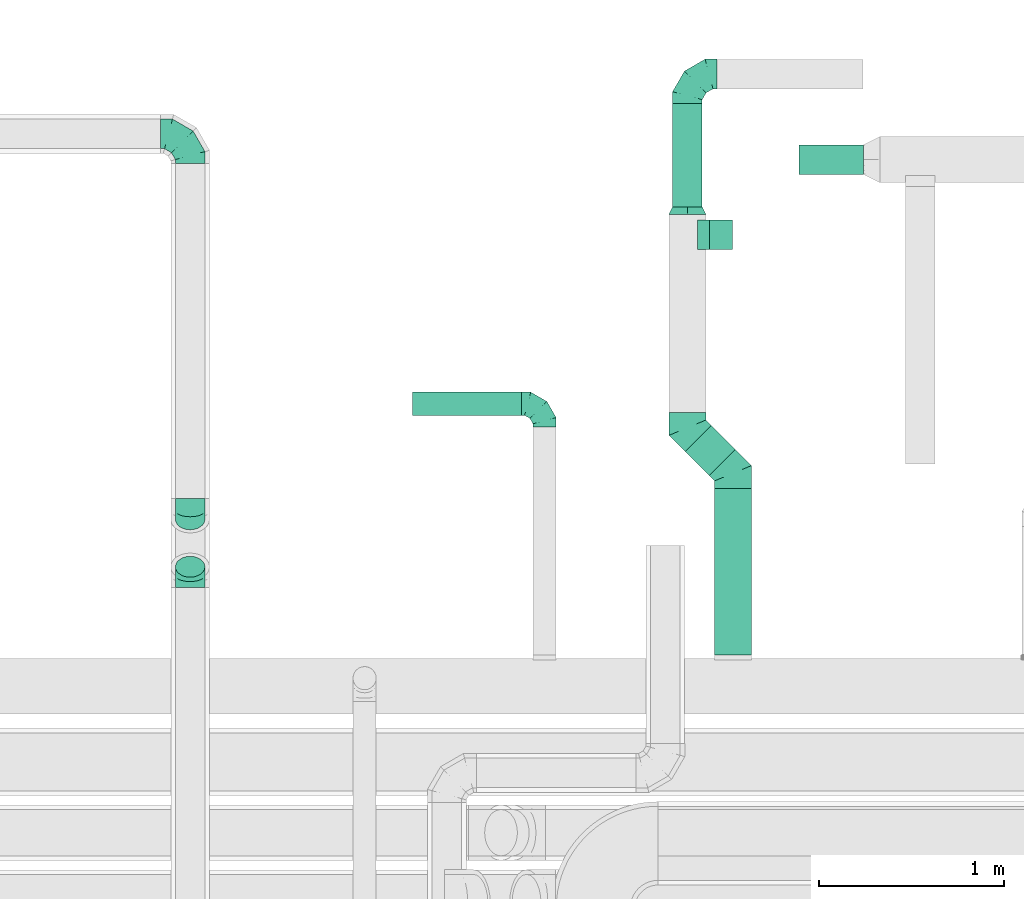
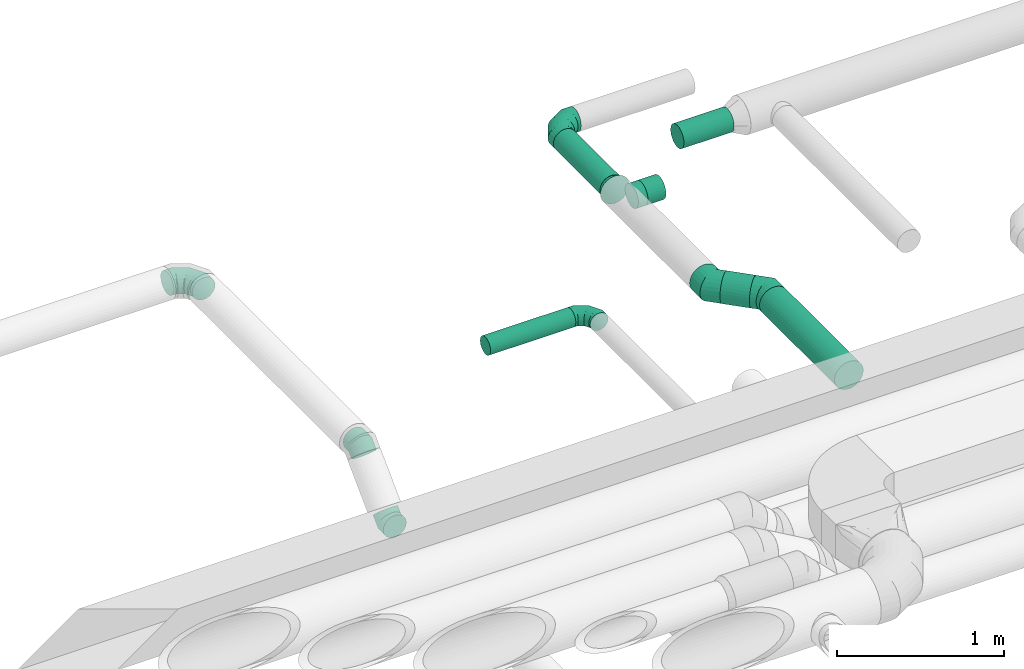
# One storey, part 77 of 92: 9 flow fittings, 6 flow segments.
"""IFC2X3 building model written with IfcOpenShell, lengths in millimetres."""

from ifc_helpers import new_model, entity, si_unit, converted_unit, derived_unit, direction, frame, origin, origin_2d_with_axis, place, context, subcontext, project, spatial, circle, extrude, faceted_brep, source, transform, mapped, material, type_object, type_shapes, element, save


model = new_model("IFC2X3")

# Units and contexts
model_context = context("Model", 3, precision=0.01, world=origin(), true_north=direction((6.12303176911189e-17, 1.0)))
body_context = subcontext(model_context, "Body", "Model", "MODEL_VIEW")
ifc_project = project(units=[si_unit("LENGTHUNIT", "METRE", prefix="MILLI"), si_unit("AREAUNIT", "SQUARE_METRE"), si_unit("VOLUMEUNIT", "CUBIC_METRE"), converted_unit("PLANEANGLEUNIT", "DEGREE", entity("IfcRatioMeasure", 0.0174532925199433), si_unit("PLANEANGLEUNIT", "RADIAN"), dimensions=[0, 0, 0, 0, 0, 0, 0]), si_unit("MASSUNIT", "GRAM", prefix="KILO"), derived_unit("MASSDENSITYUNIT", [(si_unit("MASSUNIT", "GRAM", prefix="KILO"), 1), (si_unit("LENGTHUNIT", "METRE"), -3)]), derived_unit("MOMENTOFINERTIAUNIT", [(si_unit("LENGTHUNIT", "METRE"), 4)]), si_unit("TIMEUNIT", "SECOND"), si_unit("FREQUENCYUNIT", "HERTZ"), si_unit("THERMODYNAMICTEMPERATUREUNIT", "DEGREE_CELSIUS"), derived_unit("THERMALTRANSMITTANCEUNIT", [(si_unit("MASSUNIT", "GRAM", prefix="KILO"), 1), (si_unit("THERMODYNAMICTEMPERATUREUNIT", "KELVIN"), -1), (si_unit("TIMEUNIT", "SECOND"), -3)]), derived_unit("VOLUMETRICFLOWRATEUNIT", [(si_unit("LENGTHUNIT", "METRE"), 3), (si_unit("TIMEUNIT", "SECOND"), -1)]), derived_unit("MASSFLOWRATEUNIT", [(si_unit("MASSUNIT", "GRAM", prefix="KILO"), 1), (si_unit("TIMEUNIT", "SECOND"), -1)]), derived_unit("ROTATIONALFREQUENCYUNIT", [(si_unit("TIMEUNIT", "SECOND"), -1)]), si_unit("ELECTRICCURRENTUNIT", "AMPERE"), si_unit("ELECTRICVOLTAGEUNIT", "VOLT"), si_unit("POWERUNIT", "WATT"), si_unit("FORCEUNIT", "NEWTON", prefix="KILO"), si_unit("ILLUMINANCEUNIT", "LUX"), si_unit("LUMINOUSFLUXUNIT", "LUMEN"), si_unit("LUMINOUSINTENSITYUNIT", "CANDELA"), derived_unit("USERDEFINED", [(si_unit("MASSUNIT", "GRAM", prefix="KILO"), -1), (si_unit("LENGTHUNIT", "METRE"), -2), (si_unit("TIMEUNIT", "SECOND"), 3), (si_unit("LUMINOUSFLUXUNIT", "LUMEN"), 1)]), derived_unit("LINEARVELOCITYUNIT", [(si_unit("LENGTHUNIT", "METRE"), 1), (si_unit("TIMEUNIT", "SECOND"), -1)]), si_unit("PRESSUREUNIT", "PASCAL"), derived_unit("USERDEFINED", [(si_unit("LENGTHUNIT", "METRE"), -2), (si_unit("MASSUNIT", "GRAM", prefix="KILO"), 1), (si_unit("TIMEUNIT", "SECOND"), -2)]), derived_unit("LINEARFORCEUNIT", [(si_unit("MASSUNIT", "GRAM", prefix="KILO"), 1), (si_unit("LENGTHUNIT", "METRE"), 1), (si_unit("TIMEUNIT", "SECOND"), -2), (si_unit("LENGTHUNIT", "METRE"), -1)]), derived_unit("PLANARFORCEUNIT", [(si_unit("MASSUNIT", "GRAM", prefix="KILO"), 1), (si_unit("LENGTHUNIT", "METRE"), 1), (si_unit("TIMEUNIT", "SECOND"), -2), (si_unit("LENGTHUNIT", "METRE"), -2)])], contexts=[model_context])

# Site, building, storey
site_placement = place(None, origin())
site = spatial("IfcSite", under=ifc_project, at=site_placement, CompositionType="ELEMENT")
building_placement = place(site_placement, origin())
building = spatial("IfcBuilding", under=site, at=building_placement, CompositionType="ELEMENT")
storey_placement = place(building_placement, frame((0.0, 0.0, 4200.0)))
storey = spatial("IfcBuildingStorey", under=building, at=storey_placement, CompositionType="ELEMENT", Elevation=4200.0)

# Flow segments
duct_segment_type = type_object("IfcDuctSegmentType", PredefinedType="NOTDEFINED")
flow_segment_1_placement = place(storey_placement, frame((46242.34, 17593.01, 3235.9)))
element("IfcFlowSegment", 1, at=flow_segment_1_placement, inside=storey, type_object=duct_segment_type, context=body_context, shape_type="SweptSolid", body=[
    extrude(circle(Radius=62.5, at=origin_2d_with_axis()), frame((0.0, 64.1, 64.1), z_axis=(1.0, 0.0, 0.0), x_axis=(0.0, 1.0, 0.0)), (0.0, 0.0, 1.0), 590.000000000022),
])
flow_segment_2_placement = place(storey_placement, frame((47873.4, 16299.51, 3198.4)))
element("IfcFlowSegment", 2, at=flow_segment_2_placement, inside=storey, type_object=duct_segment_type, context=body_context, shape_type="SweptSolid", body=[
    extrude(circle(Radius=100.0, at=origin_2d_with_axis()), frame((101.6, 0.0, 101.6), z_axis=(0.0, 1.0, 0.0), x_axis=(-1.0, 0.0, 0.0)), (0.0, 0.0, 1.0), 899.170482652031),
])
flow_segment_3_placement = place(storey_placement, frame((47715.06, 17267.8, 3198.4)))
element("IfcFlowSegment", 3, at=flow_segment_3_placement, inside=storey, type_object=duct_segment_type, context=body_context, shape_type="SweptSolid", body=[
    extrude(circle(Radius=100.0, at=origin_2d_with_axis()), frame((201.37, 72.31, 101.6), z_axis=(-0.707106781186536, 0.707106781186559, 0.0), x_axis=(0.707106781186559, 0.707106781186536, 0.0)), (0.0, 0.0, 1.0), 182.518234109865),
])
flow_segment_4_placement = place(storey_placement, frame((47848.78, 18488.98, 3218.4)))
element("IfcFlowSegment", 4, at=flow_segment_4_placement, inside=storey, type_object=duct_segment_type, context=body_context, shape_type="SweptSolid", body=[
    extrude(circle(Radius=80.0, at=origin_2d_with_axis()), frame((0.0, 81.6, 81.6), z_axis=(1.0, 0.0, 0.0), x_axis=(0.0, -1.0, 0.0)), (0.0, 0.0, 1.0), 124.99999999998),
])
flow_segment_5_placement = place(storey_placement, frame((47647.19, 18720.04, 3218.4)))
element("IfcFlowSegment", 5, at=flow_segment_5_placement, inside=storey, type_object=duct_segment_type, context=body_context, shape_type="SweptSolid", body=[
    extrude(circle(Radius=80.0, at=origin_2d_with_axis()), frame((81.6, 0.0, 81.6), z_axis=(0.0, 1.0, 0.0), x_axis=(1.0, 0.0, 0.0)), (0.0, 0.0, 1.0), 558.813624953033),
])
flow_segment_6_placement = place(storey_placement, frame((48332.43, 18895.01, 3218.4)))
element("IfcFlowSegment", 6, at=flow_segment_6_placement, inside=storey, type_object=duct_segment_type, context=body_context, shape_type="SweptSolid", body=[
    extrude(circle(Radius=80.0, at=origin_2d_with_axis()), frame((0.0, 81.6, 81.6), z_axis=(1.0, 0.0, 0.0), x_axis=(0.0, 1.0, 0.0)), (0.0, 0.0, 1.0), 347.571574792076),
])

# Flow fittings
ifc_material = material()
duct_fitting_type_1 = type_object("IfcDuctFittingType", PredefinedType="NOTDEFINED", material=ifc_material)
shared_shape_1 = source(origin(), body_context, "Body", "Brep", [
    faceted_brep([(-160.0, 0.0, -80.0), (-160.0, -20.71, -77.27), (-160.0, -40.0, -69.28), (-160.0, -56.57, -56.57), (-160.0, -69.28, -40.0), (-160.0, -77.27, -20.71), (-160.0, -80.0, 0.0), (-160.0, -77.27, 20.71), (-160.0, -69.28, 40.0), (-160.0, -56.57, 56.57), (-160.0, -40.0, 69.28), (-160.0, -20.71, 77.27), (-160.0, 0.0, 80.0), (-160.0, 20.71, 77.27), (-160.0, 40.0, 69.28), (-160.0, 56.57, 56.57), (-160.0, 69.28, 40.0), (-160.0, 77.27, 20.71), (-160.0, 80.0, 0.0), (-160.0, 77.27, -20.71), (-160.0, 69.28, -40.0), (-160.0, 56.57, -56.57), (-160.0, 40.0, -69.28), (-160.0, 20.71, -77.27), (-122.68, 20.71, 77.27), (-127.85, 40.0, 69.28), (-117.13, 0.0, 80.0), (-132.29, 56.57, 56.57), (-137.83, 77.27, 20.71), (-138.56, 80.0, 0.0), (-135.69, 69.28, 40.0), (-135.69, 69.28, -40.0), (-132.29, 56.57, -56.57), (-137.83, 77.27, -20.71), (-122.68, 20.71, -77.27), (-117.13, 0.0, -80.0), (-127.85, 40.0, -69.28), (-111.58, -20.71, -77.27), (-106.41, -40.0, -69.28), (-101.97, -56.57, -56.57), (-98.56, -69.28, -40.0), (-96.42, -77.27, -20.71), (-95.69, -80.0, 0.0), (-96.42, -77.27, 20.71), (-98.56, -69.28, 40.0), (-101.97, -56.57, 56.57), (-106.41, -40.0, 69.28), (-111.58, -20.71, 77.27), (-58.03, 58.03, 77.27), (-72.15, 72.15, 69.28), (-42.87, 42.87, 80.0), (-84.28, 84.28, 56.57), (-93.59, 93.59, 40.0), (-99.44, 99.44, 20.71), (-101.44, 101.44, 0.0), (-99.44, 99.44, -20.71), (-93.59, 93.59, -40.0), (-84.28, 84.28, -56.57), (-58.03, 58.03, -77.27), (-42.87, 42.87, -80.0), (-72.15, 72.15, -69.28), (-27.71, 27.71, -77.27), (-13.59, 13.59, -69.28), (-1.46, 1.46, -56.57), (7.85, -7.85, -40.0), (13.7, -13.7, -20.71), (15.69, -15.69, 0.0), (13.7, -13.7, 20.71), (7.85, -7.85, 40.0), (-1.46, 1.46, 56.57), (-13.59, 13.59, 69.28), (-27.71, 27.71, 77.27), (-20.71, 122.68, 77.27), (-40.0, 127.85, 69.28), (0.0, 117.13, 80.0), (-56.57, 132.29, 56.57), (-69.28, 135.69, 40.0), (-77.27, 137.83, 20.71), (-80.0, 138.56, 0.0), (-77.27, 137.83, -20.71), (-69.28, 135.69, -40.0), (-56.57, 132.29, -56.57), (-20.71, 122.68, -77.27), (0.0, 117.13, -80.0), (-40.0, 127.85, -69.28), (20.71, 111.58, -77.27), (40.0, 106.41, -69.28), (56.57, 101.97, -56.57), (69.28, 98.56, -40.0), (77.27, 96.42, -20.71), (80.0, 95.69, 0.0), (77.27, 96.42, 20.71), (69.28, 98.56, 40.0), (56.57, 101.97, 56.57), (40.0, 106.41, 69.28), (20.71, 111.58, 77.27), (-20.71, 160.0, -77.27), (-40.0, 160.0, -69.28), (-56.57, 160.0, -56.57), (-69.28, 160.0, -40.0), (-77.27, 160.0, -20.71), (-80.0, 160.0, 0.0), (-77.27, 160.0, 20.71), (-69.28, 160.0, 40.0), (-56.57, 160.0, 56.57), (-40.0, 160.0, 69.28), (-20.71, 160.0, 77.27), (0.0, 160.0, 80.0), (20.71, 160.0, 77.27), (40.0, 160.0, 69.28), (56.57, 160.0, 56.57), (69.28, 160.0, 40.0), (77.27, 160.0, 20.71), (80.0, 160.0, 0.0), (77.27, 160.0, -20.71), (69.28, 160.0, -40.0), (56.57, 160.0, -56.57), (40.0, 160.0, -69.28), (20.71, 160.0, -77.27), (0.0, 160.0, -80.0)], [[[0, 1, 2, 3, 4, 5, 6, 7, 8, 9, 10, 11, 12, 13, 14, 15, 16, 17, 18, 19, 20, 21, 22, 23]], [[24, 25, 14, 13]], [[26, 24, 13, 12]], [[14, 25, 27, 15]], [[28, 29, 18, 17]], [[30, 28, 17, 16]], [[15, 27, 30, 16]], [[20, 31, 32, 21]], [[33, 31, 20, 19]], [[18, 29, 33, 19]], [[34, 35, 0, 23]], [[36, 34, 23, 22]], [[32, 36, 22, 21]], [[1, 0, 35, 37]], [[2, 1, 37, 38]], [[3, 2, 38, 39]], [[5, 4, 40, 41]], [[6, 5, 41, 42]], [[39, 40, 4, 3]], [[6, 42, 43, 7]], [[7, 43, 44, 8]], [[8, 44, 45, 9]], [[9, 45, 46, 10]], [[10, 46, 47, 11]], [[26, 12, 11, 47]], [[48, 49, 25, 24]], [[50, 48, 24, 26]], [[27, 25, 49, 51]], [[52, 53, 28, 30]], [[51, 52, 30, 27]], [[29, 28, 53, 54]], [[55, 56, 31, 33]], [[54, 55, 33, 29]], [[32, 31, 56, 57]], [[58, 59, 35, 34]], [[60, 58, 34, 36]], [[57, 60, 36, 32]], [[37, 35, 59, 61]], [[38, 37, 61, 62]], [[39, 38, 62, 63]], [[41, 40, 64, 65]], [[42, 41, 65, 66]], [[63, 64, 40, 39]], [[43, 42, 66, 67]], [[44, 43, 67, 68]], [[68, 69, 45, 44]], [[46, 45, 69, 70]], [[47, 46, 70, 71]], [[26, 47, 71, 50]], [[72, 73, 49, 48]], [[74, 72, 48, 50]], [[51, 49, 73, 75]], [[76, 77, 53, 52]], [[75, 76, 52, 51]], [[54, 53, 77, 78]], [[79, 80, 56, 55]], [[78, 79, 55, 54]], [[57, 56, 80, 81]], [[82, 83, 59, 58]], [[84, 82, 58, 60]], [[81, 84, 60, 57]], [[61, 59, 83, 85]], [[62, 61, 85, 86]], [[63, 62, 86, 87]], [[65, 64, 88, 89]], [[66, 65, 89, 90]], [[87, 88, 64, 63]], [[67, 66, 90, 91]], [[68, 67, 91, 92]], [[92, 93, 69, 68]], [[70, 69, 93, 94]], [[71, 70, 94, 95]], [[50, 71, 95, 74]], [[96, 97, 98, 99, 100, 101, 102, 103, 104, 105, 106, 107, 108, 109, 110, 111, 112, 113, 114, 115, 116, 117, 118, 119]], [[72, 74, 107, 106]], [[73, 72, 106, 105]], [[75, 73, 105, 104]], [[77, 76, 103, 102]], [[78, 77, 102, 101]], [[75, 104, 103, 76]], [[78, 101, 100, 79]], [[79, 100, 99, 80]], [[80, 99, 98, 81]], [[84, 97, 96, 82]], [[82, 96, 119, 83]], [[84, 81, 98, 97]], [[118, 117, 86, 85]], [[119, 118, 85, 83]], [[116, 87, 86, 117]], [[88, 115, 114, 89]], [[89, 114, 113, 90]], [[115, 88, 87, 116]], [[112, 111, 92, 91]], [[113, 112, 91, 90]], [[111, 110, 93, 92]], [[95, 94, 109, 108]], [[74, 95, 108, 107]], [[110, 109, 94, 93]]]),
])
type_shapes(duct_fitting_type_1, [shared_shape_1])
for number, where, z_axis, x_axis in (
    (7, (47728.78, 19438.85, 3300.0), (0.0, 0.0, 1.0), (-1.0, 0.0, 0.0)),
    (8, (45042.31, 19115.23, 3350.09), (0.0, -4.32875225825151e-05, 1.0), (0.0, 1.0, 4.32875225825151e-05)),
):
    element("IfcFlowFitting", number, at=place(storey_placement, frame(where, z_axis=z_axis, x_axis=x_axis)), inside=storey, type_object=duct_fitting_type_1, material=ifc_material, context=body_context, shape_type="MappedRepresentation", body=[
        mapped(shared_shape_1, transform((0.0, 0.0, 0.0), scale=1.0)),
    ])
duct_fitting_type_2 = type_object("IfcDuctFittingType", PredefinedType="NOTDEFINED", material=ifc_material)
shared_shape_2 = source(origin(), body_context, "Body", "Brep", [
    faceted_brep([(-125.0, 0.0, -62.5), (-125.0, -16.18, -60.37), (-125.0, -31.25, -54.13), (-125.0, -44.19, -44.19), (-125.0, -54.13, -31.25), (-125.0, -60.37, -16.18), (-125.0, -62.5, 0.0), (-125.0, -60.37, 16.18), (-125.0, -54.13, 31.25), (-125.0, -44.19, 44.19), (-125.0, -31.25, 54.13), (-125.0, -16.18, 60.37), (-125.0, 0.0, 62.5), (-125.0, 16.18, 60.37), (-125.0, 31.25, 54.13), (-125.0, 44.19, 44.19), (-125.0, 54.13, 31.25), (-125.0, 60.37, 16.18), (-125.0, 62.5, 0.0), (-125.0, 60.37, -16.18), (-125.0, 54.13, -31.25), (-125.0, 44.19, -44.19), (-125.0, 31.25, -54.13), (-125.0, 16.18, -60.37), (-95.84, 16.18, 60.37), (-99.88, 31.25, 54.13), (-91.51, 0.0, 62.5), (-103.35, 44.19, 44.19), (-107.68, 60.37, 16.18), (-108.25, 62.5, 0.0), (-106.01, 54.13, 31.25), (-106.01, 54.13, -31.25), (-103.35, 44.19, -44.19), (-107.68, 60.37, -16.18), (-95.84, 16.18, -60.37), (-91.51, 0.0, -62.5), (-99.88, 31.25, -54.13), (-87.17, -16.18, -60.37), (-83.13, -31.25, -54.13), (-79.66, -44.19, -44.19), (-77.0, -54.13, -31.25), (-75.33, -60.37, -16.18), (-74.76, -62.5, 0.0), (-75.33, -60.37, 16.18), (-77.0, -54.13, 31.25), (-79.66, -44.19, 44.19), (-83.13, -31.25, 54.13), (-87.17, -16.18, 60.37), (-45.34, 45.34, 60.37), (-56.37, 56.37, 54.13), (-33.49, 33.49, 62.5), (-65.85, 65.85, 44.19), (-73.12, 73.12, 31.25), (-77.69, 77.69, 16.18), (-79.25, 79.25, 0.0), (-77.69, 77.69, -16.18), (-73.12, 73.12, -31.25), (-65.85, 65.85, -44.19), (-45.34, 45.34, -60.37), (-33.49, 33.49, -62.5), (-56.37, 56.37, -54.13), (-21.65, 21.65, -60.37), (-10.62, 10.62, -54.13), (-1.14, 1.14, -44.19), (6.13, -6.13, -31.25), (10.7, -10.7, -16.18), (12.26, -12.26, 0.0), (10.7, -10.7, 16.18), (6.13, -6.13, 31.25), (-1.14, 1.14, 44.19), (-10.62, 10.62, 54.13), (-21.65, 21.65, 60.37), (-16.18, 95.84, 60.37), (-31.25, 99.88, 54.13), (0.0, 91.51, 62.5), (-44.19, 103.35, 44.19), (-54.13, 106.01, 31.25), (-60.37, 107.68, 16.18), (-62.5, 108.25, 0.0), (-60.37, 107.68, -16.18), (-54.13, 106.01, -31.25), (-44.19, 103.35, -44.19), (-16.18, 95.84, -60.37), (0.0, 91.51, -62.5), (-31.25, 99.88, -54.13), (16.18, 87.17, -60.37), (31.25, 83.13, -54.13), (44.19, 79.66, -44.19), (54.13, 77.0, -31.25), (60.37, 75.33, -16.18), (62.5, 74.76, 0.0), (60.37, 75.33, 16.18), (54.13, 77.0, 31.25), (44.19, 79.66, 44.19), (31.25, 83.13, 54.13), (16.18, 87.17, 60.37), (-16.18, 125.0, -60.37), (-31.25, 125.0, -54.13), (-44.19, 125.0, -44.19), (-54.13, 125.0, -31.25), (-60.37, 125.0, -16.18), (-62.5, 125.0, 0.0), (-60.37, 125.0, 16.18), (-54.13, 125.0, 31.25), (-44.19, 125.0, 44.19), (-31.25, 125.0, 54.13), (-16.18, 125.0, 60.37), (0.0, 125.0, 62.5), (16.18, 125.0, 60.37), (31.25, 125.0, 54.13), (44.19, 125.0, 44.19), (54.13, 125.0, 31.25), (60.37, 125.0, 16.18), (62.5, 125.0, 0.0), (60.37, 125.0, -16.18), (54.13, 125.0, -31.25), (44.19, 125.0, -44.19), (31.25, 125.0, -54.13), (16.18, 125.0, -60.37), (0.0, 125.0, -62.5)], [[[0, 1, 2, 3, 4, 5, 6, 7, 8, 9, 10, 11, 12, 13, 14, 15, 16, 17, 18, 19, 20, 21, 22, 23]], [[24, 25, 14, 13]], [[26, 24, 13, 12]], [[14, 25, 27, 15]], [[28, 29, 18, 17]], [[30, 28, 17, 16]], [[15, 27, 30, 16]], [[20, 31, 32, 21]], [[33, 31, 20, 19]], [[18, 29, 33, 19]], [[34, 35, 0, 23]], [[36, 34, 23, 22]], [[21, 32, 36, 22]], [[1, 0, 35, 37]], [[2, 1, 37, 38]], [[38, 39, 3, 2]], [[5, 4, 40, 41]], [[6, 5, 41, 42]], [[39, 40, 4, 3]], [[6, 42, 43, 7]], [[7, 43, 44, 8]], [[45, 9, 8, 44]], [[9, 45, 46, 10]], [[10, 46, 47, 11]], [[26, 12, 11, 47]], [[48, 49, 25, 24]], [[50, 48, 24, 26]], [[27, 25, 49, 51]], [[52, 53, 28, 30]], [[51, 52, 30, 27]], [[29, 28, 53, 54]], [[55, 56, 31, 33]], [[54, 55, 33, 29]], [[57, 32, 31, 56]], [[58, 59, 35, 34]], [[60, 58, 34, 36]], [[57, 60, 36, 32]], [[37, 35, 59, 61]], [[38, 37, 61, 62]], [[39, 38, 62, 63]], [[41, 40, 64, 65]], [[42, 41, 65, 66]], [[63, 64, 40, 39]], [[43, 42, 66, 67]], [[44, 43, 67, 68]], [[68, 69, 45, 44]], [[46, 45, 69, 70]], [[47, 46, 70, 71]], [[26, 47, 71, 50]], [[72, 73, 49, 48]], [[74, 72, 48, 50]], [[51, 49, 73, 75]], [[76, 77, 53, 52]], [[75, 76, 52, 51]], [[54, 53, 77, 78]], [[79, 80, 56, 55]], [[78, 79, 55, 54]], [[81, 57, 56, 80]], [[82, 83, 59, 58]], [[84, 82, 58, 60]], [[81, 84, 60, 57]], [[61, 59, 83, 85]], [[62, 61, 85, 86]], [[63, 62, 86, 87]], [[65, 64, 88, 89]], [[66, 65, 89, 90]], [[87, 88, 64, 63]], [[67, 66, 90, 91]], [[68, 67, 91, 92]], [[92, 93, 69, 68]], [[70, 69, 93, 94]], [[71, 70, 94, 95]], [[50, 71, 95, 74]], [[96, 97, 98, 99, 100, 101, 102, 103, 104, 105, 106, 107, 108, 109, 110, 111, 112, 113, 114, 115, 116, 117, 118, 119]], [[72, 74, 107, 106]], [[73, 72, 106, 105]], [[75, 73, 105, 104]], [[77, 76, 103, 102]], [[78, 77, 102, 101]], [[75, 104, 103, 76]], [[78, 101, 100, 79]], [[79, 100, 99, 80]], [[80, 99, 98, 81]], [[96, 119, 83, 82]], [[97, 96, 82, 84]], [[84, 81, 98, 97]], [[83, 119, 118, 85]], [[85, 118, 117, 86]], [[116, 87, 86, 117]], [[88, 115, 114, 89]], [[89, 114, 113, 90]], [[115, 88, 87, 116]], [[91, 90, 113, 112]], [[92, 91, 112, 111]], [[111, 110, 93, 92]], [[95, 94, 109, 108]], [[74, 95, 108, 107]], [[110, 109, 94, 93]]]),
])
type_shapes(duct_fitting_type_2, [shared_shape_2])
flow_fitting_1_placement = place(storey_placement, frame((46957.34, 17657.11, 3300.0), z_axis=(0.0, 0.0, 1.0), x_axis=(0.0, 1.0, 0.0)))
element("IfcFlowFitting", 9, at=flow_fitting_1_placement, inside=storey, type_object=duct_fitting_type_2, material=ifc_material, context=body_context, shape_type="MappedRepresentation", body=[
    mapped(shared_shape_2, transform((0.0, 0.0, 0.0), scale=1.0)),
])
duct_fitting_type_3 = type_object("IfcDuctFittingType", PredefinedType="NOTDEFINED", material=ifc_material)
shared_shape_3 = source(origin(), body_context, "Body", "Brep", [
    faceted_brep([(-66.27, 0.0, -80.0), (-66.27, -20.71, -77.27), (-66.27, -40.0, -69.28), (-66.27, -56.57, -56.57), (-66.27, -69.28, -40.0), (-66.27, -77.27, -20.71), (-66.27, -80.0, 0.0), (-66.27, -77.27, 20.71), (-66.27, -69.28, 40.0), (-66.27, -56.57, 56.57), (-66.27, -40.0, 69.28), (-66.27, -20.71, 77.27), (-66.27, 0.0, 80.0), (-66.27, 20.71, 77.27), (-66.27, 40.0, 69.28), (-66.27, 56.57, 56.57), (-66.27, 69.28, 40.0), (-66.27, 77.27, 20.71), (-66.27, 80.0, 0.0), (-66.27, 77.27, -20.71), (-66.27, 69.28, -40.0), (-66.27, 56.57, -56.57), (-66.27, 40.0, -69.28), (-66.27, 20.71, -77.27), (-8.58, 20.71, 77.27), (-16.57, 40.0, 69.28), (0.0, 0.0, 80.0), (-23.43, 56.57, 56.57), (-28.7, 69.28, 40.0), (-32.01, 77.27, 20.71), (-33.14, 80.0, 0.0), (-32.01, 77.27, -20.71), (-28.7, 69.28, -40.0), (-23.43, 56.57, -56.57), (-8.58, 20.71, -77.27), (0.0, 0.0, -80.0), (-16.57, 40.0, -69.28), (8.58, -20.71, -77.27), (16.57, -40.0, -69.28), (23.43, -56.57, -56.57), (28.7, -69.28, -40.0), (32.01, -77.27, -20.71), (33.14, -80.0, 0.0), (32.01, -77.27, 20.71), (28.7, -69.28, 40.0), (23.43, -56.57, 56.57), (16.57, -40.0, 69.28), (8.58, -20.71, 77.27), (46.86, 46.86, 80.0), (32.22, 61.5, 77.27), (18.58, 75.15, 69.28), (6.86, 86.86, 56.57), (-2.13, 95.85, 40.0), (-7.78, 101.5, 20.71), (-9.71, 103.43, 0.0), (-7.78, 101.5, -20.71), (-2.13, 95.85, -40.0), (6.86, 86.86, -56.57), (18.58, 75.15, -69.28), (32.22, 61.5, -77.27), (46.86, 46.86, -80.0), (61.5, 32.22, -77.27), (75.15, 18.58, -69.28), (86.86, 6.86, -56.57), (95.85, -2.13, -40.0), (101.5, -7.78, -20.71), (103.43, -9.71, 0.0), (101.5, -7.78, 20.71), (95.85, -2.13, 40.0), (86.86, 6.86, 56.57), (75.15, 18.58, 69.28), (61.5, 32.22, 77.27)], [[[0, 1, 2, 3, 4, 5, 6, 7, 8, 9, 10, 11, 12, 13, 14, 15, 16, 17, 18, 19, 20, 21, 22, 23]], [[24, 25, 14, 13]], [[26, 24, 13, 12]], [[14, 25, 27, 15]], [[28, 29, 17, 16]], [[28, 16, 15, 27]], [[30, 18, 17, 29]], [[31, 32, 20, 19]], [[30, 31, 19, 18]], [[32, 33, 21, 20]], [[34, 35, 0, 23]], [[36, 34, 23, 22]], [[33, 36, 22, 21]], [[1, 0, 35, 37]], [[2, 1, 37, 38]], [[38, 39, 3, 2]], [[5, 4, 40, 41]], [[6, 5, 41, 42]], [[39, 40, 4, 3]], [[6, 42, 43, 7]], [[7, 43, 44, 8]], [[8, 44, 45, 9]], [[9, 45, 46, 10]], [[10, 46, 47, 11]], [[26, 12, 11, 47]], [[24, 26, 48, 49]], [[25, 24, 49, 50]], [[27, 25, 50, 51]], [[29, 28, 52, 53]], [[30, 29, 53, 54]], [[51, 52, 28, 27]], [[30, 54, 55, 31]], [[31, 55, 56, 32]], [[57, 33, 32, 56]], [[36, 58, 59, 34]], [[34, 59, 60, 35]], [[58, 36, 33, 57]], [[35, 60, 61, 37]], [[37, 61, 62, 38]], [[63, 39, 38, 62]], [[40, 64, 65, 41]], [[41, 65, 66, 42]], [[64, 40, 39, 63]], [[43, 42, 66, 67]], [[44, 43, 67, 68]], [[68, 69, 45, 44]], [[47, 46, 70, 71]], [[26, 47, 71, 48]], [[69, 70, 46, 45]], [[59, 58, 57, 56, 55, 54, 53, 52, 51, 50, 49, 48, 71, 70, 69, 68, 67, 66, 65, 64, 63, 62, 61, 60]]]),
])
type_shapes(duct_fitting_type_3, [shared_shape_3])
flow_fitting_2_placement = place(storey_placement, frame((45042.31, 17079.51, 3350.0), z_axis=(1.0, 0.0, 0.0), x_axis=(0.0, -1.0, -4.90810996049449e-08)))
element("IfcFlowFitting", 10, at=flow_fitting_2_placement, inside=storey, type_object=duct_fitting_type_3, material=ifc_material, context=body_context, shape_type="MappedRepresentation", body=[
    mapped(shared_shape_3, transform((0.0, 0.0, 0.0), scale=1.0)),
])
duct_fitting_type_4 = type_object("IfcDuctFittingType", PredefinedType="NOTDEFINED", material=ifc_material)
type_shapes(duct_fitting_type_4, [shared_shape_3])
flow_fitting_3_placement = place(storey_placement, frame((45042.31, 16729.51, 3000.0), z_axis=(-1.0, 0.0, 0.0), x_axis=(0.0, -0.707106781186503, -0.707106781186592)))
element("IfcFlowFitting", 11, at=flow_fitting_3_placement, inside=storey, type_object=duct_fitting_type_4, material=ifc_material, context=body_context, shape_type="MappedRepresentation", body=[
    mapped(shared_shape_3, transform((0.0, 0.0, 0.0), scale=1.0)),
])
duct_fitting_type_5 = type_object("IfcDuctFittingType", PredefinedType="NOTDEFINED", material=ifc_material)
shared_shape_4 = source(origin(), body_context, "Body", "Brep", [
    faceted_brep([(-82.84, 0.0, -100.0), (-82.84, -25.88, -96.59), (-82.84, -50.0, -86.6), (-82.84, -70.71, -70.71), (-82.84, -86.6, -50.0), (-82.84, -96.59, -25.88), (-82.84, -100.0, 0.0), (-82.84, -96.59, 25.88), (-82.84, -86.6, 50.0), (-82.84, -70.71, 70.71), (-82.84, -50.0, 86.6), (-82.84, -25.88, 96.59), (-82.84, 0.0, 100.0), (-82.84, 25.88, 96.59), (-82.84, 50.0, 86.6), (-82.84, 70.71, 70.71), (-82.84, 86.6, 50.0), (-82.84, 96.59, 25.88), (-82.84, 100.0, 0.0), (-82.84, 96.59, -25.88), (-82.84, 86.6, -50.0), (-82.84, 70.71, -70.71), (-82.84, 50.0, -86.6), (-82.84, 25.88, -96.59), (-10.72, 25.88, 96.59), (-20.71, 50.0, 86.6), (0.0, 0.0, 100.0), (-29.29, 70.71, 70.71), (-35.87, 86.6, 50.0), (-40.01, 96.59, 25.88), (-41.42, 100.0, 0.0), (-40.01, 96.59, -25.88), (-35.87, 86.6, -50.0), (-29.29, 70.71, -70.71), (-10.72, 25.88, -96.59), (0.0, 0.0, -100.0), (-20.71, 50.0, -86.6), (10.72, -25.88, -96.59), (20.71, -50.0, -86.6), (29.29, -70.71, -70.71), (35.87, -86.6, -50.0), (40.01, -96.59, -25.88), (41.42, -100.0, 0.0), (40.01, -96.59, 25.88), (35.87, -86.6, 50.0), (29.29, -70.71, 70.71), (20.71, -50.0, 86.6), (10.72, -25.88, 96.59), (58.58, 58.58, 100.0), (40.28, 76.88, 96.59), (23.22, 93.93, 86.6), (8.58, 108.58, 70.71), (-2.66, 119.82, 50.0), (-9.72, 126.88, 25.88), (-12.13, 129.29, 0.0), (-9.72, 126.88, -25.88), (-2.66, 119.82, -50.0), (8.58, 108.58, -70.71), (23.22, 93.93, -86.6), (40.28, 76.88, -96.59), (58.58, 58.58, -100.0), (76.88, 40.28, -96.59), (93.93, 23.22, -86.6), (108.58, 8.58, -70.71), (119.82, -2.66, -50.0), (126.88, -9.72, -25.88), (129.29, -12.13, 0.0), (126.88, -9.72, 25.88), (119.82, -2.66, 50.0), (108.58, 8.58, 70.71), (93.93, 23.22, 86.6), (76.88, 40.28, 96.59)], [[[0, 1, 2, 3, 4, 5, 6, 7, 8, 9, 10, 11, 12, 13, 14, 15, 16, 17, 18, 19, 20, 21, 22, 23]], [[24, 25, 14, 13]], [[26, 24, 13, 12]], [[14, 25, 27, 15]], [[28, 29, 17, 16]], [[28, 16, 15, 27]], [[30, 18, 17, 29]], [[31, 32, 20, 19]], [[30, 31, 19, 18]], [[32, 33, 21, 20]], [[34, 35, 0, 23]], [[36, 34, 23, 22]], [[33, 36, 22, 21]], [[1, 0, 35, 37]], [[2, 1, 37, 38]], [[38, 39, 3, 2]], [[5, 4, 40, 41]], [[6, 5, 41, 42]], [[39, 40, 4, 3]], [[6, 42, 43, 7]], [[7, 43, 44, 8]], [[8, 44, 45, 9]], [[9, 45, 46, 10]], [[10, 46, 47, 11]], [[26, 12, 11, 47]], [[24, 26, 48, 49]], [[25, 24, 49, 50]], [[27, 25, 50, 51]], [[29, 28, 52, 53]], [[30, 29, 53, 54]], [[51, 52, 28, 27]], [[30, 54, 55, 31]], [[31, 55, 56, 32]], [[57, 33, 32, 56]], [[36, 58, 59, 34]], [[34, 59, 60, 35]], [[58, 36, 33, 57]], [[35, 60, 61, 37]], [[37, 61, 62, 38]], [[63, 39, 38, 62]], [[40, 64, 65, 41]], [[41, 65, 66, 42]], [[64, 40, 39, 63]], [[43, 42, 66, 67]], [[44, 43, 67, 68]], [[68, 69, 45, 44]], [[47, 46, 70, 71]], [[26, 47, 71, 48]], [[69, 70, 46, 45]], [[59, 58, 57, 56, 55, 54, 53, 52, 51, 50, 49, 48, 71, 70, 69, 68, 67, 66, 65, 64, 63, 62, 61, 60]]]),
])
type_shapes(duct_fitting_type_5, [shared_shape_4])
for number, where, z_axis, x_axis in (
    (12, (47728.78, 17527.74, 3300.0), (0.0, 0.0, 1.0), (0.0, -1.0, 0.0)),
    (13, (47975.0, 17281.53, 3300.0), (0.0, 0.0, 1.0), (0.0, 1.0, 0.0)),
):
    element("IfcFlowFitting", number, at=place(storey_placement, frame(where, z_axis=z_axis, x_axis=x_axis)), inside=storey, type_object=duct_fitting_type_5, material=ifc_material, context=body_context, shape_type="MappedRepresentation", body=[
        mapped(shared_shape_4, transform((0.0, 0.0, 0.0), scale=1.0)),
    ])
duct_fitting_type_6 = type_object("IfcDuctFittingType", PredefinedType="NOTDEFINED", material=ifc_material)
shared_shape_5 = source(origin(), body_context, "Body", "Brep", [
    faceted_brep([(40.0, -73.91, 30.61), (40.0, -76.96, 15.31), (40.0, -80.0, 0.0), (40.0, -76.96, -15.31), (40.0, -73.91, -30.61), (40.0, -65.24, -43.59), (40.0, -56.57, -56.57), (40.0, -43.59, -65.24), (40.0, -30.61, -73.91), (40.0, -15.31, -76.96), (40.0, 0.0, -80.0), (40.0, 15.31, -76.96), (40.0, 30.61, -73.91), (40.0, 43.59, -65.24), (40.0, 56.57, -56.57), (40.0, 65.24, -43.59), (40.0, 73.91, -30.61), (40.0, 76.96, -15.31), (40.0, 80.0, 0.0), (40.0, 76.96, 15.31), (40.0, 73.91, 30.61), (40.0, 65.24, 43.59), (40.0, 56.57, 56.57), (40.0, 43.59, 65.24), (40.0, 30.61, 73.91), (40.0, 15.31, 76.96), (40.0, 0.0, 80.0), (40.0, -15.31, 76.96), (40.0, -30.61, 73.91), (40.0, -43.59, 65.24), (40.0, -56.57, 56.57), (40.0, -65.24, 43.59), (0.0, -100.0, 0.0), (0.0, -95.11, 30.9), (0.0, -80.9, 58.78), (0.0, -58.78, 80.9), (0.0, -30.9, 95.11), (0.0, 0.0, 100.0), (0.0, 30.9, 95.11), (0.0, 58.78, 80.9), (0.0, 80.9, 58.78), (0.0, 95.11, 30.9), (0.0, 100.0, 0.0), (0.0, 95.11, -30.9), (0.0, 80.9, -58.78), (0.0, 58.78, -80.9), (0.0, 30.9, -95.11), (0.0, 0.0, -100.0), (0.0, -30.9, -95.11), (0.0, -58.78, -80.9), (0.0, -80.9, -58.78), (0.0, -95.11, -30.9)], [[[0, 1, 2, 3, 4, 5, 6, 7, 8, 9, 10, 11, 12, 13, 14, 15, 16, 17, 18, 19, 20, 21, 22, 23, 24, 25, 26, 27, 28, 29, 30, 31]], [[32, 33, 34, 35, 36, 37, 38, 39, 40, 41, 42, 43, 44, 45, 46, 47, 48, 49, 50, 51]], [[37, 25, 38]], [[25, 24, 38]], [[24, 39, 38]], [[41, 20, 19]], [[25, 37, 26]], [[39, 24, 23, 22]], [[42, 19, 18]], [[20, 40, 22, 21]], [[41, 40, 20]], [[42, 41, 19]], [[22, 40, 39]], [[32, 1, 33]], [[1, 0, 33]], [[0, 34, 33]], [[36, 28, 27]], [[1, 32, 2]], [[34, 0, 31, 30]], [[37, 27, 26]], [[28, 35, 30, 29]], [[36, 35, 28]], [[37, 36, 27]], [[30, 35, 34]], [[47, 9, 48]], [[9, 8, 48]], [[8, 49, 48]], [[51, 4, 3]], [[9, 47, 10]], [[49, 8, 7, 6]], [[32, 3, 2]], [[4, 50, 6, 5]], [[51, 50, 4]], [[32, 51, 3]], [[6, 50, 49]], [[42, 17, 43]], [[17, 16, 43]], [[16, 44, 43]], [[46, 12, 11]], [[17, 42, 18]], [[44, 16, 15, 14]], [[47, 11, 10]], [[12, 45, 14, 13]], [[46, 45, 12]], [[47, 46, 11]], [[14, 45, 44]]]),
])
type_shapes(duct_fitting_type_6, [shared_shape_5])
flow_fitting_4_placement = place(storey_placement, frame((47728.78, 18680.04, 3300.0), z_axis=(0.0, 0.0, 1.0), x_axis=(0.0, 1.0, 0.0)))
element("IfcFlowFitting", 14, at=flow_fitting_4_placement, inside=storey, type_object=duct_fitting_type_6, material=ifc_material, context=body_context, shape_type="MappedRepresentation", body=[
    mapped(shared_shape_5, transform((0.0, 0.0, 0.0), scale=1.0)),
])
duct_fitting_type_7 = type_object("IfcDuctFittingType", PredefinedType="NOTDEFINED", material=ifc_material)
shared_shape_6 = source(origin(), body_context, "Body", "Brep", [
    faceted_brep([(20.0, 20.71, -77.27), (20.0, 40.0, -69.28), (20.0, 56.57, -56.57), (20.0, 69.28, -40.0), (20.0, 77.27, -20.71), (20.0, 80.0, 0.0), (20.0, 77.27, 20.71), (20.0, 69.28, 40.0), (20.0, 56.57, 56.57), (20.0, 40.0, 69.28), (20.0, 20.71, 77.27), (20.0, 0.0, 80.0), (20.0, -20.71, 77.27), (20.0, -40.0, 69.28), (20.0, -56.57, 56.57), (20.0, -69.28, 40.0), (20.0, -77.27, 20.71), (20.0, -80.0, 0.0), (20.0, -77.27, -20.71), (20.0, -69.28, -40.0), (20.0, -56.57, -56.57), (20.0, -40.0, -69.28), (20.0, -20.71, -77.27), (20.0, 0.0, -80.0), (0.0, 0.0, 80.0), (0.0, 20.71, 77.27), (-46.1, 20.71, 77.27), (-46.1, 0.0, 80.0), (0.0, 40.0, 69.28), (-46.1, 40.0, 69.28), (0.0, 56.57, 56.57), (-46.1, 56.57, 56.57), (0.0, 69.28, 40.0), (0.0, 77.27, 20.71), (-46.1, 77.27, 20.71), (-46.1, 69.28, 40.0), (0.0, 80.0, 0.0), (-46.1, 80.0, 0.0), (0.0, 77.27, -20.71), (-46.1, 77.27, -20.71), (0.0, 69.28, -40.0), (-46.1, 69.28, -40.0), (0.0, 56.57, -56.57), (-46.1, 56.57, -56.57), (0.0, 40.0, -69.28), (0.0, 20.71, -77.27), (-46.1, 20.71, -77.27), (-46.1, 40.0, -69.28), (0.0, 0.0, -80.0), (-46.1, 0.0, -80.0), (0.0, -20.71, -77.27), (-46.1, -20.71, -77.27), (0.0, -40.0, -69.28), (-46.1, -40.0, -69.28), (0.0, -56.57, -56.57), (-46.1, -56.57, -56.57), (0.0, -69.28, -40.0), (0.0, -77.27, -20.71), (-46.1, -77.27, -20.71), (-46.1, -69.28, -40.0), (0.0, -80.0, 0.0), (-46.1, -80.0, 0.0), (0.0, -77.27, 20.71), (-46.1, -77.27, 20.71), (0.0, -69.28, 40.0), (-46.1, -69.28, 40.0), (0.0, -56.57, 56.57), (-46.1, -56.57, 56.57), (0.0, -40.0, 69.28), (0.0, -20.71, 77.27), (-46.1, -20.71, 77.27), (-46.1, -40.0, 69.28)], [[[0, 1, 2, 3, 4, 5, 6, 7, 8, 9, 10, 11, 12, 13, 14, 15, 16, 17, 18, 19, 20, 21, 22, 23]], [[24, 11, 10, 25, 26, 27]], [[25, 10, 9, 28, 29, 26]], [[28, 9, 8, 30, 31, 29]], [[32, 7, 6, 33, 34, 35]], [[33, 6, 5, 36, 37, 34]], [[30, 8, 7, 32, 35, 31]], [[36, 5, 4, 38, 39, 37]], [[38, 4, 3, 40, 41, 39]], [[40, 3, 2, 42, 43, 41]], [[44, 1, 0, 45, 46, 47]], [[45, 0, 23, 48, 49, 46]], [[42, 2, 1, 44, 47, 43]], [[48, 23, 22, 50, 51, 49]], [[50, 22, 21, 52, 53, 51]], [[52, 21, 20, 54, 55, 53]], [[56, 19, 18, 57, 58, 59]], [[57, 18, 17, 60, 61, 58]], [[54, 20, 19, 56, 59, 55]], [[60, 17, 16, 62, 63, 61]], [[62, 16, 15, 64, 65, 63]], [[64, 15, 14, 66, 67, 65]], [[68, 13, 12, 69, 70, 71]], [[69, 12, 11, 24, 27, 70]], [[66, 14, 13, 68, 71, 67]], [[49, 51, 53, 55, 59, 58, 61, 63, 65, 67, 71, 70, 27, 26, 29, 31, 35, 34, 37, 39, 41, 43, 47, 46]]]),
])
type_shapes(duct_fitting_type_7, [shared_shape_6])
flow_fitting_5_placement = place(storey_placement, frame((47828.78, 18570.58, 3300.0), z_axis=(0.0, 0.0, -1.0), x_axis=(1.0, 0.0, 0.0)))
element("IfcFlowFitting", 15, at=flow_fitting_5_placement, inside=storey, type_object=duct_fitting_type_7, material=ifc_material, context=body_context, shape_type="MappedRepresentation", body=[
    mapped(shared_shape_6, transform((0.0, 0.0, 0.0), scale=1.0)),
])

save(model, "model.ifc")
